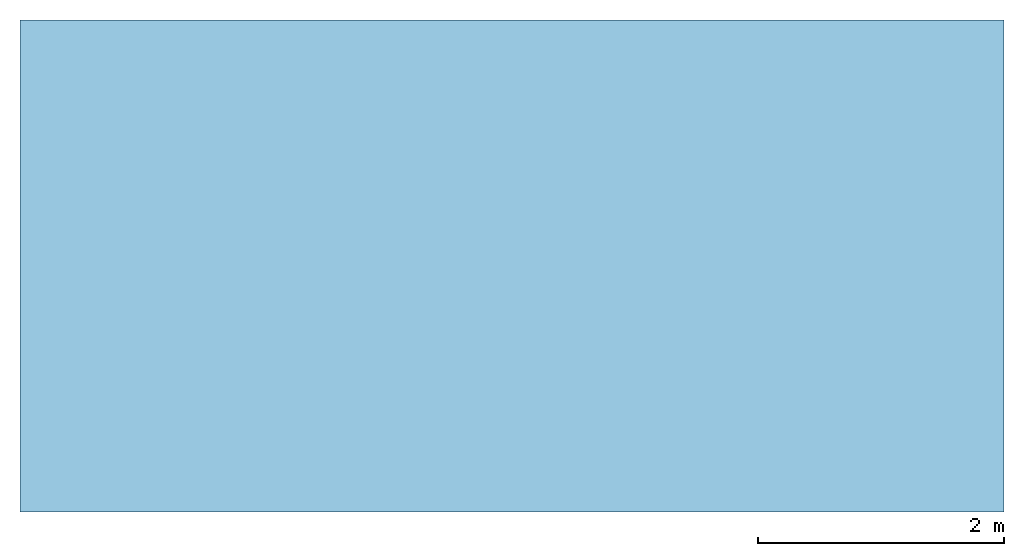
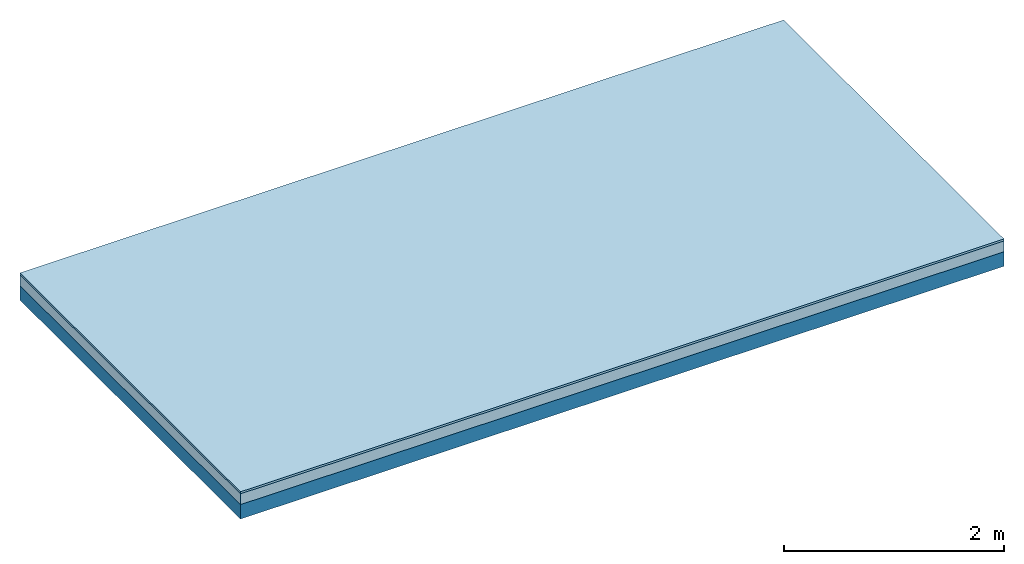
# One storey: 2 plates, 1 member, 1 element without a shape of its own.
"""IFC4 building model written with IfcOpenShell, lengths in metres."""

from ifc_helpers import new_model, si_unit, derived_unit, direction, frame, frame_2d, origin, origin_with_axes, place, context, project, spatial, rectangle, extrude, material, layer, layer_set, type_object, element, aggregate, save


model = new_model("IFC4")

# Units and contexts
plan_context = context("Plan", 3, precision=1e-05, world=origin(), true_north=direction((0.0, 1.0)))
model_context = context("Model", 3, precision=1e-05, world=origin(), true_north=direction((0.0, 1.0)))
ifc_project = project(units=[si_unit("LENGTHUNIT", "METRE"), derived_unit("SOUNDPRESSUREUNIT", [(si_unit("PRESSUREUNIT", "PASCAL", prefix="MICRO"), 0)]), si_unit("ENERGYUNIT", "JOULE", prefix="MEGA"), si_unit("MASSUNIT", "GRAM", prefix="KILO"), derived_unit("THERMALTRANSMITTANCEUNIT", [(si_unit("POWERUNIT", "WATT"), 1), (si_unit("AREAUNIT", "SQUARE_METRE"), -1), (si_unit("THERMODYNAMICTEMPERATUREUNIT", "KELVIN"), -1)]), derived_unit("AREADENSITYUNIT", [(si_unit("MASSUNIT", "GRAM", prefix="KILO"), 1), (si_unit("AREAUNIT", "SQUARE_METRE"), -1)]), derived_unit("USERDEFINED", [(si_unit("ENERGYUNIT", "JOULE", prefix="MEGA"), 1), (si_unit("AREAUNIT", "SQUARE_METRE"), -1)])], contexts=[plan_context, model_context])

# Site, building, storey
site = spatial("IfcSite", under=ifc_project)
building_placement = place(None, origin())
building = spatial("IfcBuilding", under=site, at=building_placement)
storey_placement = place(building_placement, origin())
storey = spatial("IfcBuildingStorey", under=building, at=storey_placement)

# Slab, member, plates
ifc_material_1 = material(Name="OSB3 panel", Category="07.013")
ifc_layer_1 = layer(ifc_material_1, 0.022, Name="On-material")
ifc_material_2 = material()
ifc_layer_2 = layer(ifc_material_2, 0.12, Name="Impact sound insulation")
ifc_material_3 = material(Name="no composite action")
ifc_layer_3 = layer(ifc_material_3, 0.0, Name="Bond")
ifc_layer_4 = layer(None, 0.16, Name="Supporting structure")
ifc_layer_set = layer_set([ifc_layer_1, ifc_layer_2, ifc_layer_3, ifc_layer_4])
slab_type = type_object("IfcSlabType", Name="A2175", PredefinedType="NOTDEFINED", material=ifc_layer_set)
slab_placement = place(None, frame((0.0, 0.0, 0.0), z_axis=(0.0, 0.0, -1.0), x_axis=(1.0, 0.0, 0.0)))
slab = element("IfcSlab", 1, at=slab_placement, inside=storey, type_object=slab_type, material=ifc_layer_set, Name="Slab #1")
ifc_material_4 = material(Name="Solid timber panel")
member_placement = place(slab_placement, origin())
member = element("IfcMember", 2, at=member_placement, material=ifc_material_4, Name="Supporting structure", context=plan_context, shape_type="SweptSolid", body=[
    extrude(rectangle(XDim=1.0, YDim=0.16, at=frame_2d((0.5, 0.08), x_axis=(1.0, 0.0))), frame((0.0, 4.0, 0.142), z_axis=(0.0, -1.0, 0.0), x_axis=(1.0, 0.0, 0.0)), (0.0, 0.0, 1.0), 4.0),
    extrude(rectangle(XDim=1.0, YDim=0.16, at=frame_2d((0.5, 0.08), x_axis=(1.0, 0.0))), frame((1.0, 4.0, 0.142), z_axis=(0.0, -1.0, 0.0), x_axis=(1.0, 0.0, 0.0)), (0.0, 0.0, 1.0), 4.0),
    extrude(rectangle(XDim=1.0, YDim=0.16, at=frame_2d((0.5, 0.08), x_axis=(1.0, 0.0))), frame((2.0, 4.0, 0.142), z_axis=(0.0, -1.0, 0.0), x_axis=(1.0, 0.0, 0.0)), (0.0, 0.0, 1.0), 4.0),
    extrude(rectangle(XDim=1.0, YDim=0.16, at=frame_2d((0.5, 0.08), x_axis=(1.0, 0.0))), frame((3.0, 4.0, 0.142), z_axis=(0.0, -1.0, 0.0), x_axis=(1.0, 0.0, 0.0)), (0.0, 0.0, 1.0), 4.0),
    extrude(rectangle(XDim=1.0, YDim=0.16, at=frame_2d((0.5, 0.08), x_axis=(1.0, 0.0))), frame((4.0, 4.0, 0.142), z_axis=(0.0, -1.0, 0.0), x_axis=(1.0, 0.0, 0.0)), (0.0, 0.0, 1.0), 4.0),
    extrude(rectangle(XDim=1.0, YDim=0.16, at=frame_2d((0.5, 0.08), x_axis=(1.0, 0.0))), frame((5.0, 4.0, 0.142), z_axis=(0.0, -1.0, 0.0), x_axis=(1.0, 0.0, 0.0)), (0.0, 0.0, 1.0), 4.0),
    extrude(rectangle(XDim=1.0, YDim=0.16, at=frame_2d((0.5, 0.08), x_axis=(1.0, 0.0))), frame((6.0, 4.0, 0.142), z_axis=(0.0, -1.0, 0.0), x_axis=(1.0, 0.0, 0.0)), (0.0, 0.0, 1.0), 4.0),
    extrude(rectangle(XDim=1.0, YDim=0.16, at=frame_2d((0.5, 0.08), x_axis=(1.0, 0.0))), frame((7.0, 4.0, 0.142), z_axis=(0.0, -1.0, 0.0), x_axis=(1.0, 0.0, 0.0)), (0.0, 0.0, 1.0), 4.0),
])
plate_1_placement = place(slab_placement, origin())
plate_1 = element("IfcPlate", 3, at=plate_1_placement, material=ifc_material_1, Name="On-material", context=plan_context, shape_type="SweptSolid", body=[
    extrude(rectangle(XDim=8.0, YDim=4.0, at=frame_2d((4.0, 2.0), x_axis=(1.0, 0.0))), origin_with_axes(), (0.0, 0.0, 1.0), 0.022),
])
plate_2_placement = place(slab_placement, origin())
plate_2 = element("IfcPlate", 4, at=plate_2_placement, material=ifc_material_2, Name="Impact sound insulation", context=plan_context, shape_type="SweptSolid", body=[
    extrude(rectangle(XDim=8.0, YDim=4.0, at=frame_2d((4.0, 2.0), x_axis=(1.0, 0.0))), frame((0.0, 0.0, 0.022), z_axis=(0.0, 0.0, 1.0), x_axis=(1.0, 0.0, 0.0)), (0.0, 0.0, 1.0), 0.12),
])
aggregate(slab, [plate_1, plate_2, member])

save(model, "model.ifc")
